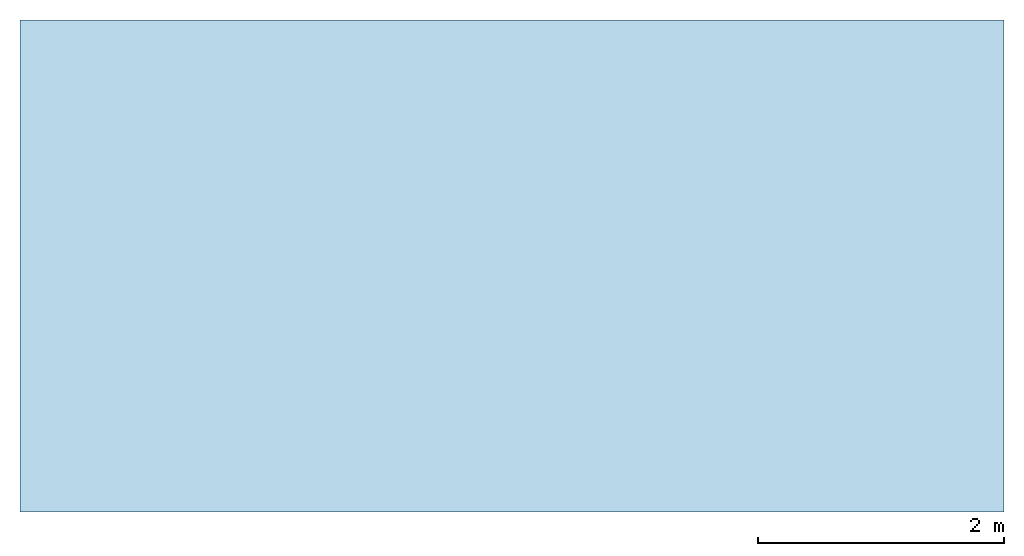
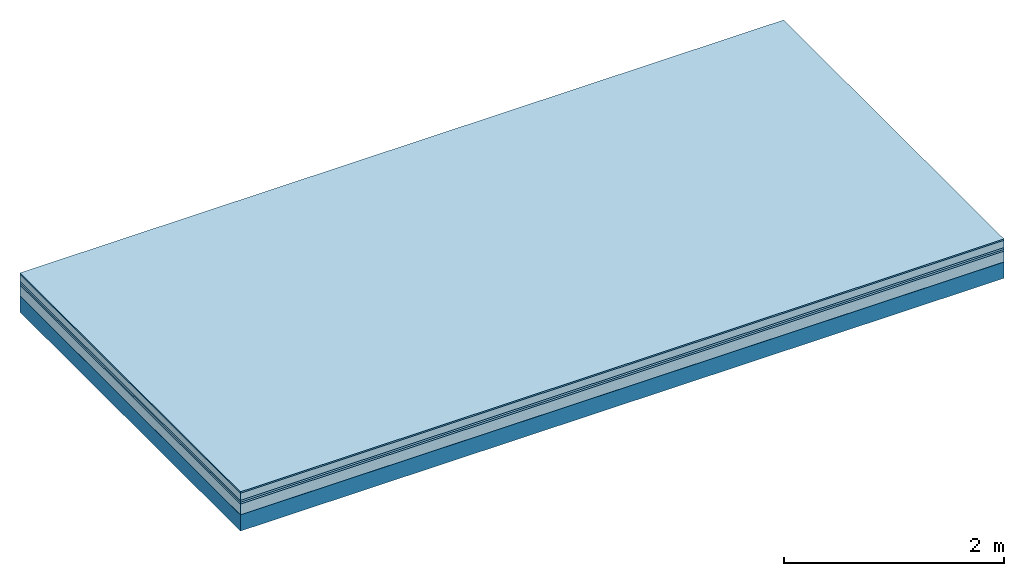
# One storey: 6 plates, 1 member, 1 element without a shape of its own.
"""IFC4 building model written with IfcOpenShell, lengths in metres."""

from ifc_helpers import new_model, si_unit, derived_unit, direction, frame, frame_2d, origin, origin_with_axes, place, context, project, spatial, rectangle, extrude, material, layer, layer_set, type_object, element, aggregate, save


model = new_model("IFC4")

# Units and contexts
plan_context = context("Plan", 3, precision=1e-05, world=origin(), true_north=direction((0.0, 1.0)))
model_context = context("Model", 3, precision=1e-05, world=origin(), true_north=direction((0.0, 1.0)))
ifc_project = project(units=[si_unit("LENGTHUNIT", "METRE"), derived_unit("SOUNDPRESSUREUNIT", [(si_unit("PRESSUREUNIT", "PASCAL", prefix="MICRO"), 0)]), si_unit("ENERGYUNIT", "JOULE", prefix="MEGA"), si_unit("MASSUNIT", "GRAM", prefix="KILO"), derived_unit("THERMALTRANSMITTANCEUNIT", [(si_unit("POWERUNIT", "WATT"), 1), (si_unit("AREAUNIT", "SQUARE_METRE"), -1), (si_unit("THERMODYNAMICTEMPERATUREUNIT", "KELVIN"), -1)]), derived_unit("AREADENSITYUNIT", [(si_unit("MASSUNIT", "GRAM", prefix="KILO"), 1), (si_unit("AREAUNIT", "SQUARE_METRE"), -1)]), derived_unit("USERDEFINED", [(si_unit("ENERGYUNIT", "JOULE", prefix="MEGA"), 1), (si_unit("AREAUNIT", "SQUARE_METRE"), -1)])], contexts=[plan_context, model_context])

# Site, building, storey
site = spatial("IfcSite", under=ifc_project)
building_placement = place(None, origin())
building = spatial("IfcBuilding", under=site, at=building_placement)
storey_placement = place(building_placement, origin())
storey = spatial("IfcBuildingStorey", under=building, at=storey_placement)

# Slab, member, plates
ifc_material_1 = material(Category="11.013")
ifc_layer_1 = layer(ifc_material_1, 0.015, Name="Flooring")
ifc_material_2 = material(Name="Cement screed", Category="04.006")
ifc_layer_2 = layer(ifc_material_2, 0.08, Name="On-material")
ifc_material_3 = material(Name="Wood fiber generic product", Category="10.009")
ifc_layer_3 = layer(ifc_material_3, 0.02, Name="Impact sound insulation")
ifc_material_4 = material()
ifc_layer_4 = layer(ifc_material_4, 0.02, Name="Additional insulation")
ifc_material_5 = material(Category="03.011")
ifc_layer_5 = layer(ifc_material_5, 0.12, Name="on Supporting structure")
ifc_material_6 = material(Name="protection", Category="09.007")
ifc_layer_6 = layer(ifc_material_6, 0.0005, Name="Sub-floor")
ifc_material_7 = material(Name="no composite action")
ifc_layer_7 = layer(ifc_material_7, 0.0, Name="Bond")
ifc_layer_8 = layer(None, 0.18, Name="Supporting structure")
ifc_layer_set = layer_set([ifc_layer_1, ifc_layer_2, ifc_layer_3, ifc_layer_4, ifc_layer_5, ifc_layer_6, ifc_layer_7, ifc_layer_8])
slab_type = type_object("IfcSlabType", Name="A2081", PredefinedType="NOTDEFINED", material=ifc_layer_set)
slab_placement = place(None, frame((0.0, 0.0, 0.0), z_axis=(0.0, 0.0, -1.0), x_axis=(1.0, 0.0, 0.0)))
slab = element("IfcSlab", 1, at=slab_placement, inside=storey, type_object=slab_type, material=ifc_layer_set, Name="Slab #1")
ifc_material_8 = material(Name="Solid timber panel")
member_placement = place(slab_placement, origin())
member = element("IfcMember", 2, at=member_placement, material=ifc_material_8, Name="Supporting structure", context=plan_context, shape_type="SweptSolid", body=[
    extrude(rectangle(XDim=1.0, YDim=0.18, at=frame_2d((0.5, 0.09), x_axis=(1.0, 0.0))), frame((0.0, 4.0, 0.2555), z_axis=(0.0, -1.0, 0.0), x_axis=(1.0, 0.0, 0.0)), (0.0, 0.0, 1.0), 4.0),
    extrude(rectangle(XDim=1.0, YDim=0.18, at=frame_2d((0.5, 0.09), x_axis=(1.0, 0.0))), frame((1.0, 4.0, 0.2555), z_axis=(0.0, -1.0, 0.0), x_axis=(1.0, 0.0, 0.0)), (0.0, 0.0, 1.0), 4.0),
    extrude(rectangle(XDim=1.0, YDim=0.18, at=frame_2d((0.5, 0.09), x_axis=(1.0, 0.0))), frame((2.0, 4.0, 0.2555), z_axis=(0.0, -1.0, 0.0), x_axis=(1.0, 0.0, 0.0)), (0.0, 0.0, 1.0), 4.0),
    extrude(rectangle(XDim=1.0, YDim=0.18, at=frame_2d((0.5, 0.09), x_axis=(1.0, 0.0))), frame((3.0, 4.0, 0.2555), z_axis=(0.0, -1.0, 0.0), x_axis=(1.0, 0.0, 0.0)), (0.0, 0.0, 1.0), 4.0),
    extrude(rectangle(XDim=1.0, YDim=0.18, at=frame_2d((0.5, 0.09), x_axis=(1.0, 0.0))), frame((4.0, 4.0, 0.2555), z_axis=(0.0, -1.0, 0.0), x_axis=(1.0, 0.0, 0.0)), (0.0, 0.0, 1.0), 4.0),
    extrude(rectangle(XDim=1.0, YDim=0.18, at=frame_2d((0.5, 0.09), x_axis=(1.0, 0.0))), frame((5.0, 4.0, 0.2555), z_axis=(0.0, -1.0, 0.0), x_axis=(1.0, 0.0, 0.0)), (0.0, 0.0, 1.0), 4.0),
    extrude(rectangle(XDim=1.0, YDim=0.18, at=frame_2d((0.5, 0.09), x_axis=(1.0, 0.0))), frame((6.0, 4.0, 0.2555), z_axis=(0.0, -1.0, 0.0), x_axis=(1.0, 0.0, 0.0)), (0.0, 0.0, 1.0), 4.0),
    extrude(rectangle(XDim=1.0, YDim=0.18, at=frame_2d((0.5, 0.09), x_axis=(1.0, 0.0))), frame((7.0, 4.0, 0.2555), z_axis=(0.0, -1.0, 0.0), x_axis=(1.0, 0.0, 0.0)), (0.0, 0.0, 1.0), 4.0),
])
plate_1_placement = place(slab_placement, origin())
plate_1 = element("IfcPlate", 3, at=plate_1_placement, material=ifc_material_1, Name="Flooring", context=plan_context, shape_type="SweptSolid", body=[
    extrude(rectangle(XDim=8.0, YDim=4.0, at=frame_2d((4.0, 2.0), x_axis=(1.0, 0.0))), origin_with_axes(), (0.0, 0.0, 1.0), 0.015),
])
plate_2_placement = place(slab_placement, origin())
plate_2 = element("IfcPlate", 4, at=plate_2_placement, material=ifc_material_2, Name="On-material", context=plan_context, shape_type="SweptSolid", body=[
    extrude(rectangle(XDim=8.0, YDim=4.0, at=frame_2d((4.0, 2.0), x_axis=(1.0, 0.0))), frame((0.0, 0.0, 0.015), z_axis=(0.0, 0.0, 1.0), x_axis=(1.0, 0.0, 0.0)), (0.0, 0.0, 1.0), 0.08),
])
plate_3_placement = place(slab_placement, origin())
plate_3 = element("IfcPlate", 5, at=plate_3_placement, material=ifc_material_3, Name="Impact sound insulation", context=plan_context, shape_type="SweptSolid", body=[
    extrude(rectangle(XDim=8.0, YDim=4.0, at=frame_2d((4.0, 2.0), x_axis=(1.0, 0.0))), frame((0.0, 0.0, 0.095), z_axis=(0.0, 0.0, 1.0), x_axis=(1.0, 0.0, 0.0)), (0.0, 0.0, 1.0), 0.02),
])
plate_4_placement = place(slab_placement, origin())
plate_4 = element("IfcPlate", 6, at=plate_4_placement, material=ifc_material_4, Name="Additional insulation", context=plan_context, shape_type="SweptSolid", body=[
    extrude(rectangle(XDim=8.0, YDim=4.0, at=frame_2d((4.0, 2.0), x_axis=(1.0, 0.0))), frame((0.0, 0.0, 0.115), z_axis=(0.0, 0.0, 1.0), x_axis=(1.0, 0.0, 0.0)), (0.0, 0.0, 1.0), 0.02),
])
plate_5_placement = place(slab_placement, origin())
plate_5 = element("IfcPlate", 7, at=plate_5_placement, material=ifc_material_5, Name="on Supporting structure", context=plan_context, shape_type="SweptSolid", body=[
    extrude(rectangle(XDim=8.0, YDim=4.0, at=frame_2d((4.0, 2.0), x_axis=(1.0, 0.0))), frame((0.0, 0.0, 0.135), z_axis=(0.0, 0.0, 1.0), x_axis=(1.0, 0.0, 0.0)), (0.0, 0.0, 1.0), 0.12),
])
plate_6_placement = place(slab_placement, origin())
plate_6 = element("IfcPlate", 8, at=plate_6_placement, material=ifc_material_6, Name="Sub-floor", context=plan_context, shape_type="SweptSolid", body=[
    extrude(rectangle(XDim=8.0, YDim=4.0, at=frame_2d((4.0, 2.0), x_axis=(1.0, 0.0))), frame((0.0, 0.0, 0.255), z_axis=(0.0, 0.0, 1.0), x_axis=(1.0, 0.0, 0.0)), (0.0, 0.0, 1.0), 0.0005),
])
aggregate(slab, [plate_1, plate_2, plate_3, plate_4, plate_5, plate_6, member])

save(model, "model.ifc")
